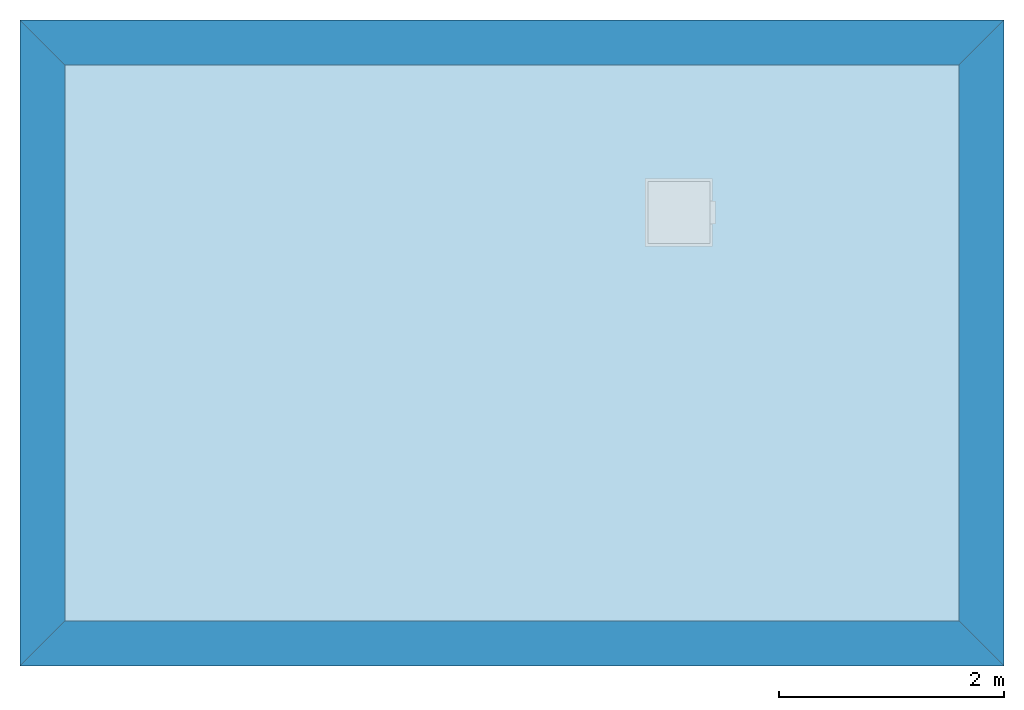
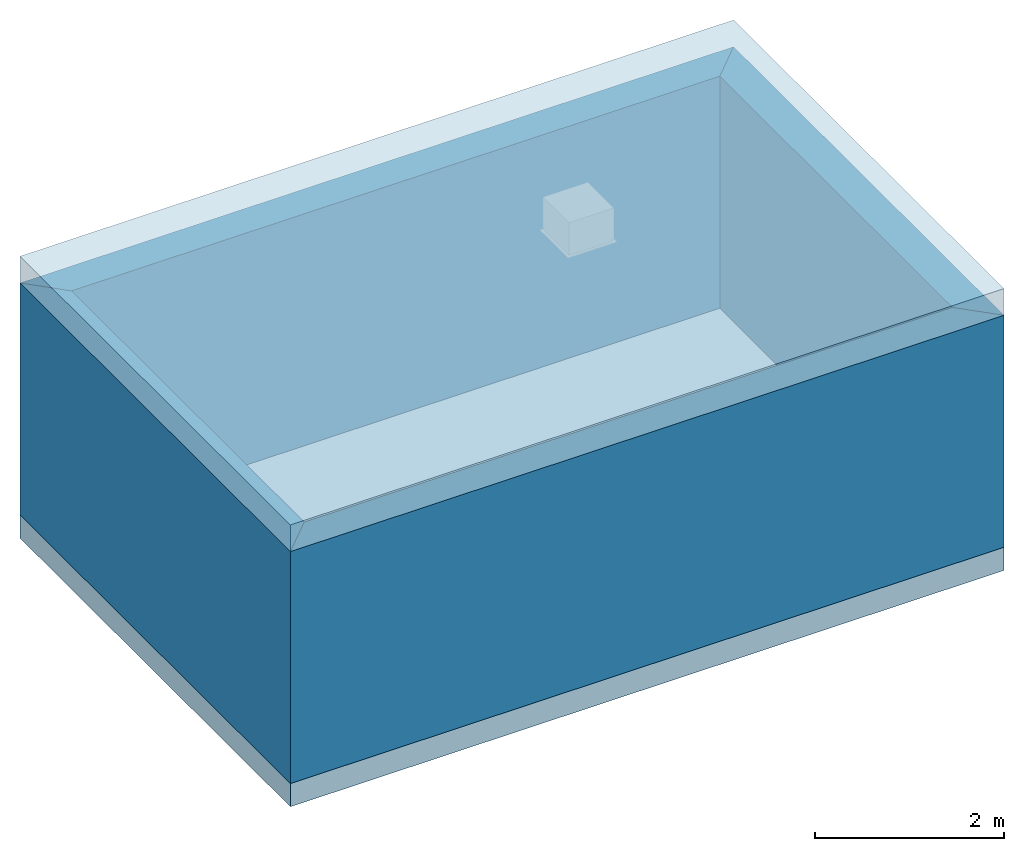
# One storey, part 1 of 2: 4 walls, 2 slabs.
"""IFC4 building model written with IfcOpenShell, lengths in metres."""

from ifc_helpers import new_model, entity, si_unit, converted_unit, derived_unit, direction, frame, origin_with_axes, place, context, subcontext, project, spatial, polyline, outline, extrude, material, layer, layer_set, layer_usage, type_object, element, save


model = new_model("IFC4")

# Units and contexts
model_context = context("Model", 3, precision=1e-05, world=origin_with_axes(), true_north=direction((0.0, 1.0)))
plan_context = context("Plan", 3, precision=1e-05, world=origin_with_axes(), true_north=direction((0.0, 1.0)))
body_context = subcontext(model_context, "Body", "Model", "MODEL_VIEW")
ifc_project = project(units=[si_unit("LENGTHUNIT", "METRE"), si_unit("AREAUNIT", "SQUARE_METRE"), si_unit("VOLUMEUNIT", "CUBIC_METRE"), converted_unit("PLANEANGLEUNIT", "DEGREE", entity("IfcPlaneAngleMeasure", 0.0174532925199), si_unit("PLANEANGLEUNIT", "RADIAN"), dimensions=[0, 0, 0, 0, 0, 0, 0]), si_unit("SOLIDANGLEUNIT", "STERADIAN"), converted_unit("TIMEUNIT", "Year", entity("IfcTimeMeasure", 31556926.0), si_unit("TIMEUNIT", "SECOND"), dimensions=[0, 0, 1, 0, 0, 0, 0]), si_unit("MASSUNIT", "GRAM", prefix="KILO"), si_unit("THERMODYNAMICTEMPERATUREUNIT", "DEGREE_CELSIUS"), si_unit("LUMINOUSINTENSITYUNIT", "LUMEN"), si_unit("ENERGYUNIT", "JOULE", prefix="MEGA"), derived_unit("THERMALCONDUCTANCEUNIT", [(si_unit("POWERUNIT", "WATT"), 1), (si_unit("LENGTHUNIT", "METRE"), -1), (si_unit("THERMODYNAMICTEMPERATUREUNIT", "KELVIN"), -1)]), derived_unit("SPECIFICHEATCAPACITYUNIT", [(si_unit("ENERGYUNIT", "JOULE"), 1), (si_unit("MASSUNIT", "GRAM", prefix="KILO"), -1), (si_unit("THERMODYNAMICTEMPERATUREUNIT", "KELVIN"), -1)]), derived_unit("MASSDENSITYUNIT", [(si_unit("MASSUNIT", "GRAM", prefix="KILO"), 1), (si_unit("VOLUMEUNIT", "CUBIC_METRE"), -1)])], contexts=[model_context, plan_context])

# Site, building, storey
site_placement = place(None, origin_with_axes())
site = spatial("IfcSite", under=ifc_project, at=site_placement, CompositionType="ELEMENT")
building_placement = place(site_placement, origin_with_axes())
building = spatial("IfcBuilding", under=site, at=building_placement, Name="Test-Building", CompositionType="ELEMENT")
storey_placement = place(building_placement, origin_with_axes())
storey = spatial("IfcBuildingStorey", under=building, at=storey_placement, Name="EG", CompositionType="ELEMENT", Elevation=0.0)

# Slabs
ifc_material_1 = material(Name="ALLGEMEIN")
ifc_layer_1 = layer(ifc_material_1, 0.3, ventilated="UNKNOWN", Name="Component 1")
ifc_layer_set_1 = layer_set([ifc_layer_1], Name="ALLGEMEIN - 0.3")
ifc_layer_usage_1 = layer_usage(ifc_layer_set_1, "AXIS3", "NEGATIVE", 0.3)
slab_type_1 = type_object("IfcSlabType", Name="ALLGEMEIN - 300", PredefinedType="FLOOR")
slab_1_placement = place(storey_placement, origin_with_axes())
element("IfcSlab", 1, at=slab_1_placement, inside=storey, type_object=slab_type_1, material=ifc_layer_usage_1, Name="Decke-001", PredefinedType="FLOOR", context=body_context, shape_type="SweptSolid", body=[
    extrude(outline(polyline([(0.0, 0.0), (8.73, 0.0), (8.73, 5.73), (0.0, 5.73), (0.0, 0.0)])), frame((0.0, 0.0, -0.3), z_axis=(0.0, 0.0, 1.0), x_axis=(1.0, 0.0, 0.0)), (0.0, 0.0, 1.0), 0.3),
])
ifc_layer_2 = layer(ifc_material_1, 0.344999999329, ventilated="UNKNOWN", Name="Component 1")
ifc_layer_set_2 = layer_set([ifc_layer_2], Name="ALLGEMEIN - 0.345")
ifc_layer_usage_2 = layer_usage(ifc_layer_set_2, "AXIS3", "NEGATIVE", 0.344999999329)
slab_type_2 = type_object("IfcSlabType", Name="ALLGEMEIN - 345", PredefinedType="ROOF")
slab_2_placement = place(storey_placement, frame((0.0, 0.0, 3.0), z_axis=(0.0, 0.0, 1.0), x_axis=(1.0, 0.0, 0.0)))
element("IfcSlab", 2, at=slab_2_placement, inside=storey, type_object=slab_type_2, material=ifc_layer_usage_2, Name="Dach-001", PredefinedType="ROOF", context=body_context, shape_type="SweptSolid", body=[
    extrude(outline(polyline([(0.0, 0.0), (8.73, 0.0), (8.73, 5.73), (0.0, 5.73), (0.0, 0.0)])), origin_with_axes(), (0.0, 0.0, 1.0), 0.344999999329),
])

# Walls
ifc_material_2 = material()
ifc_layer_3 = layer(ifc_material_2, 0.15, ventilated="UNKNOWN", Name="Component 1")
ifc_material_3 = material(Name="Beton, Beton")
ifc_layer_4 = layer(ifc_material_3, 0.25, ventilated="UNKNOWN", Name="Component 2")
ifc_layer_set_3 = layer_set([ifc_layer_3, ifc_layer_4], Name="KIT-Concrete-Isolation")
ifc_layer_usage_3 = layer_usage(ifc_layer_set_3, "AXIS2", "NEGATIVE", 0.0)
wall_type = type_object("IfcWallType", Name="KIT-Concrete-Isolation 400", PredefinedType="NOTDEFINED")
wall_1_placement = place(storey_placement, frame((0.0, 0.0, 0.0), z_axis=(0.0, 0.0, 1.0), x_axis=(0.0, 1.0, 0.0)))
element("IfcWallStandardCase", 3, at=wall_1_placement, inside=storey, type_object=wall_type, material=ifc_layer_usage_3, Name="Wand-003", context=body_context, shape_type="SweptSolid", body=[
    extrude(outline(polyline([(0.4, -0.4), (5.33, -0.4), (5.73, 0.0), (0.0, 0.0), (0.4, -0.4)])), origin_with_axes(), (0.0, 0.0, 1.0), 3.0),
])
ifc_layer_usage_4 = layer_usage(ifc_layer_set_3, "AXIS2", "NEGATIVE", 0.0)
wall_2_placement = place(storey_placement, frame((0.0, 5.73, 0.0), z_axis=(0.0, 0.0, 1.0), x_axis=(1.0, 0.0, 0.0)))
element("IfcWallStandardCase", 4, at=wall_2_placement, inside=storey, type_object=wall_type, material=ifc_layer_usage_4, Name="Wand-003", context=body_context, shape_type="SweptSolid", body=[
    extrude(outline(polyline([(0.4, -0.4), (8.33, -0.4), (8.73, 0.0), (0.0, 0.0), (0.4, -0.4)])), origin_with_axes(), (0.0, 0.0, 1.0), 3.0),
])
ifc_layer_usage_5 = layer_usage(ifc_layer_set_3, "AXIS2", "NEGATIVE", 0.0)
wall_3_placement = place(storey_placement, frame((8.73, 5.73, 0.0), z_axis=(0.0, 0.0, 1.0), x_axis=(0.0, -1.0, 0.0)))
element("IfcWallStandardCase", 5, at=wall_3_placement, inside=storey, type_object=wall_type, material=ifc_layer_usage_5, Name="Wand-003", context=body_context, shape_type="SweptSolid", body=[
    extrude(outline(polyline([(0.4, -0.4), (5.33, -0.4), (5.73, 0.0), (0.0, 0.0), (0.4, -0.4)])), origin_with_axes(), (0.0, 0.0, 1.0), 3.0),
])
ifc_layer_usage_6 = layer_usage(ifc_layer_set_3, "AXIS2", "NEGATIVE", 0.0)
wall_4_placement = place(storey_placement, frame((8.73, 0.0, 0.0), z_axis=(0.0, 0.0, 1.0), x_axis=(-1.0, 0.0, 0.0)))
element("IfcWallStandardCase", 6, at=wall_4_placement, inside=storey, type_object=wall_type, material=ifc_layer_usage_6, Name="Wand-003", context=body_context, shape_type="SweptSolid", body=[
    extrude(outline(polyline([(0.4, -0.4), (8.33, -0.4), (8.73, 0.0), (0.0, 0.0), (0.4, -0.4)])), origin_with_axes(), (0.0, 0.0, 1.0), 3.0),
])

save(model, "model.ifc")
